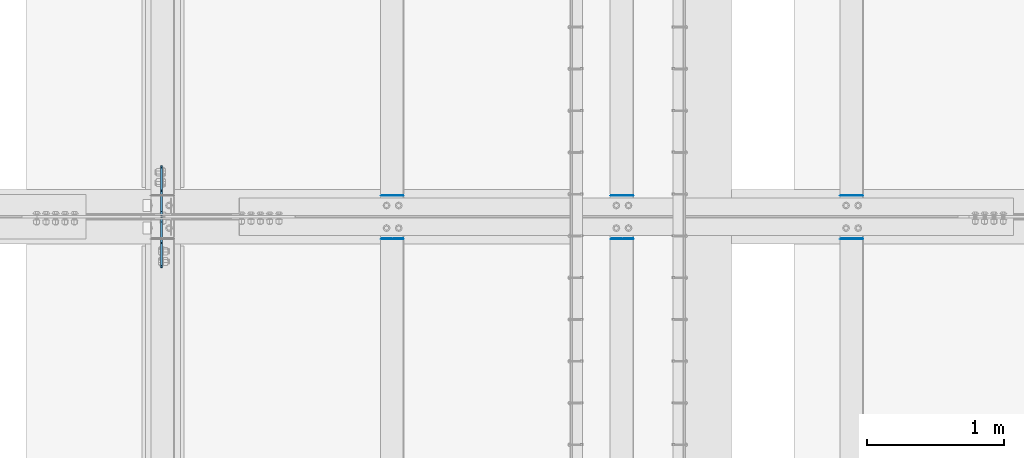
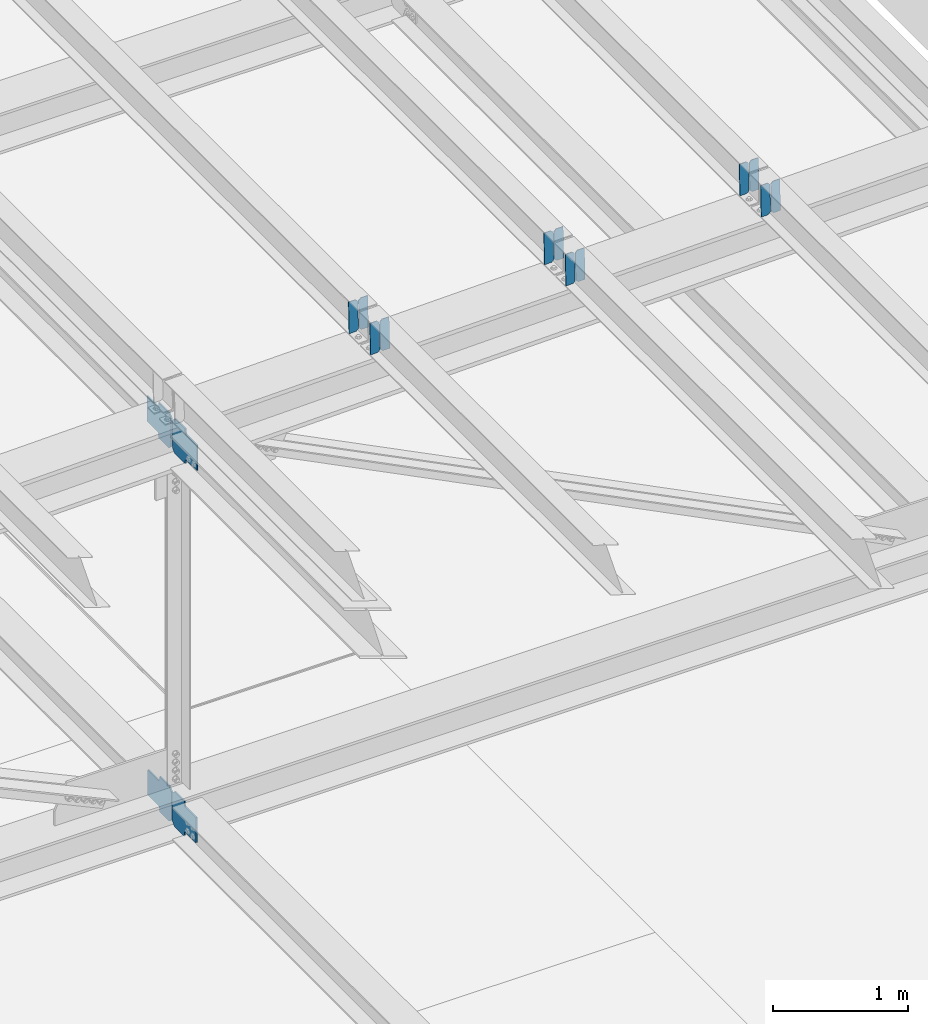
# One storey, part 3306 of 3843: 16 plates, 8 elements without a shape of their own.
"""IFC2X3 building model written with IfcOpenShell, lengths in millimetres."""

from ifc_helpers import new_model, si_unit, frame, origin_with_axes, place, context, subcontext, project, spatial, faceted_brep, material, type_object, element, aggregate, save


model = new_model("IFC2X3")

# Units and contexts
model_context = context("Model", 3, precision=1e-05, world=origin_with_axes())
body_context = subcontext(model_context, "Body", "Model", "MODEL_VIEW")
ifc_project = project(units=[si_unit("LENGTHUNIT", "METRE", prefix="MILLI"), si_unit("AREAUNIT", "SQUARE_METRE"), si_unit("VOLUMEUNIT", "CUBIC_METRE"), si_unit("MASSUNIT", "GRAM", prefix="KILO"), si_unit("TIMEUNIT", "SECOND"), si_unit("PLANEANGLEUNIT", "RADIAN"), si_unit("SOLIDANGLEUNIT", "STERADIAN"), si_unit("THERMODYNAMICTEMPERATUREUNIT", "DEGREE_CELSIUS"), si_unit("LUMINOUSINTENSITYUNIT", "LUMEN")], contexts=[model_context])

# Site, building, storey
site_placement = place(None, origin_with_axes())
site = spatial("IfcSite", under=ifc_project, at=site_placement, CompositionType="ELEMENT")
building_placement = place(site_placement, origin_with_axes())
building = spatial("IfcBuilding", under=site, at=building_placement, Name="Undefined", CompositionType="ELEMENT")
storey_placement = place(building_placement, origin_with_axes())
storey = spatial("IfcBuildingStorey", under=building, at=storey_placement, Name="Undefined", CompositionType="ELEMENT", Elevation=0.0)

# Assembly, plates
assembly_1_placement = place(storey_placement, origin_with_axes())
assembly_1 = element("IfcElementAssembly", 1, at=assembly_1_placement, inside=storey, Name="BEAM", AssemblyPlace="NOTDEFINED", PredefinedType="RIGID_FRAME")
ifc_material = material(Name="STEEL/A572-50")
plate_type_1 = type_object("IfcPlateType", PredefinedType="NOTDEFINED")
plate_1_placement = place(assembly_1_placement, frame((61042.2964783199, 50714.378682198, 46039.4825089286), z_axis=(-0.0211520982859365, -0.000347652999960701, 0.999776208896518), x_axis=(-0.999776269354799, 8.33600001439919e-06, -0.0211520960075334)))
plate_1 = element("IfcPlate", 2, at=plate_1_placement, type_object=plate_type_1, material=ifc_material, Name="PLATE", context=body_context, shape_type="Brep", body=[
    faceted_brep([(0.0, -3.17499999999927, 0.0), (6.83940015733242e-10, -3.17499999996653, 288.924999998613), (6.54836185276508e-10, 3.17500000001746, 288.924999998591), (0.0, 3.17499999999927, 0.0), (60.3250007643655, -3.17500000017753, 288.924999998606), (60.3250007643219, 3.17499999979918, 288.924999998584), (79.3750000013097, -3.17500000025029, 269.875000761494), (79.375000001266, 3.17499999972642, 269.875000761487), (79.375000000713, -3.17500000026484, 19.0499992370605), (79.3750000006985, 3.17499999971187, 19.0499992370533), (60.325000763667, -3.17500000020664, -1.45519152283669e-11), (60.3250007636234, 3.17499999977736, -3.63797880709171e-11)], [[[0, 1, 2, 3]], [[1, 4, 5, 2]], [[4, 6, 7, 5]], [[6, 8, 9, 7]], [[8, 10, 11, 9]], [[10, 0, 3, 11]], [[5, 7, 9, 11, 3, 2]], [[10, 8, 6, 4, 1, 0]]]),
])
plate_2_placement = place(assembly_1_placement, frame((60956.5906576305, 50714.3793127263, 46037.6692454375), z_axis=(-0.0211520982859365, -0.000347652999960701, 0.999776208896518), x_axis=(-0.999776269354799, 8.33600001439919e-06, -0.0211520960075334)))
plate_2 = element("IfcPlate", 3, at=plate_2_placement, type_object=plate_type_1, material=ifc_material, Name="PLATE", context=body_context, shape_type="Brep", body=[
    faceted_brep([(4.36557456851006e-11, -3.17499999998836, 19.0499992370969), (6.11180439591408e-10, -3.17499999996653, 269.875000761516), (5.96628524363041e-10, 3.17500000001746, 269.875000761502), (1.45519152283669e-11, 3.17499999998836, 19.0499992370824), (19.0499992376572, -3.17500000003201, 288.924999998606), (19.0499992376281, 3.1749999999447, 288.924999998584), (79.3750000013242, -3.17500000025029, 288.924999998591), (79.3750000013097, 3.1749999997337, 288.92499999857), (79.3750000006548, -3.17500000026484, -2.18278728425503e-11), (79.3750000006403, 3.17499999969732, -2.91038304567337e-11), (19.0499992370023, -3.17500000005384, 0.0), (19.0499992369587, 3.17499999992287, -1.45519152283669e-11)], [[[0, 1, 2, 3]], [[1, 4, 5, 2]], [[4, 6, 7, 5]], [[6, 8, 9, 7]], [[8, 10, 11, 9]], [[10, 0, 3, 11]], [[5, 7, 9, 11, 3, 2]], [[10, 8, 6, 4, 1, 0]]]),
])
aggregate(assembly_1, [plate_1, plate_2])

assembly_2_placement = place(storey_placement, origin_with_axes())
assembly_2 = element("IfcElementAssembly", 4, at=assembly_2_placement, inside=storey, Name="BEAM", AssemblyPlace="NOTDEFINED", PredefinedType="RIGID_FRAME")
plate_3_placement = place(assembly_2_placement, frame((61042.2964782849, 50397.3143925666, 46039.1367768835), z_axis=(-0.0211520975395179, -0.00180653400038137, 0.999774637208098), x_axis=(-0.999776269352655, 3.88860000353947e-05, -0.0211520620074247)))
plate_3 = element("IfcPlate", 5, at=plate_3_placement, type_object=plate_type_1, material=ifc_material, Name="PLATE", context=body_context, shape_type="Brep", body=[
    faceted_brep([(0.0, -3.17499999999927, 0.0), (6.83940015733242e-10, -3.17499999996653, 288.924999998613), (6.54836185276508e-10, 3.17500000001746, 288.924999998591), (0.0, 3.17499999999927, 0.0), (60.3250007643655, -3.17500000017753, 288.924999998606), (60.3250007643219, 3.17499999979918, 288.924999998584), (79.3750000013097, -3.17500000025029, 269.875000761494), (79.375000001266, 3.17499999972642, 269.875000761487), (79.375000000713, -3.17500000026484, 19.0499992370605), (79.3750000006985, 3.17499999971187, 19.0499992370533), (60.325000763667, -3.17500000020664, -1.45519152283669e-11), (60.3250007636234, 3.17499999977736, -3.63797880709171e-11)], [[[0, 1, 2, 3]], [[1, 4, 5, 2]], [[4, 6, 7, 5]], [[6, 8, 9, 7]], [[8, 10, 11, 9]], [[10, 0, 3, 11]], [[5, 7, 9, 11, 3, 2]], [[10, 8, 6, 4, 1, 0]]]),
])
plate_4_placement = place(assembly_2_placement, frame((60956.5906575955, 50397.3176690209, 46037.323516242), z_axis=(-0.0211520975395179, -0.00180653400038137, 0.999774637208098), x_axis=(-0.999776269352655, 3.88860000353947e-05, -0.0211520620074247)))
plate_4 = element("IfcPlate", 6, at=plate_4_placement, type_object=plate_type_1, material=ifc_material, Name="PLATE", context=body_context, shape_type="Brep", body=[
    faceted_brep([(4.36557456851006e-11, -3.17499999998836, 19.0499992370969), (6.11180439591408e-10, -3.17499999996653, 269.875000761516), (5.96628524363041e-10, 3.17500000001746, 269.875000761502), (1.45519152283669e-11, 3.17499999998836, 19.0499992370824), (19.0499992376572, -3.17500000003201, 288.924999998606), (19.0499992376281, 3.1749999999447, 288.924999998584), (79.3750000013242, -3.17500000025029, 288.924999998591), (79.3750000013097, 3.1749999997337, 288.92499999857), (79.3750000006548, -3.17500000026484, -2.18278728425503e-11), (79.3750000006403, 3.17499999969732, -2.91038304567337e-11), (19.0499992370023, -3.17500000005384, 0.0), (19.0499992369587, 3.17499999992287, -1.45519152283669e-11)], [[[0, 1, 2, 3]], [[1, 4, 5, 2]], [[4, 6, 7, 5]], [[6, 8, 9, 7]], [[8, 10, 11, 9]], [[10, 0, 3, 11]], [[5, 7, 9, 11, 3, 2]], [[10, 8, 6, 4, 1, 0]]]),
])
aggregate(assembly_2, [plate_3, plate_4])

assembly_3_placement = place(storey_placement, origin_with_axes())
assembly_3 = element("IfcElementAssembly", 7, at=assembly_3_placement, inside=storey, Name="BEAM", AssemblyPlace="NOTDEFINED", PredefinedType="RIGID_FRAME")
plate_5_placement = place(assembly_3_placement, frame((59365.8964782974, 50714.3766152781, 46001.2841898124), z_axis=(-0.0211520982357469, -0.000340721000095072, 0.999776211284018), x_axis=(-0.999776269348334, 6.33400000515396e-06, -0.0211520970073544)))
plate_5 = element("IfcPlate", 8, at=plate_5_placement, type_object=plate_type_1, material=ifc_material, Name="PLATE", context=body_context, shape_type="Brep", body=[
    faceted_brep([(0.0, -3.17499999999927, 0.0), (6.83940015733242e-10, -3.17499999996653, 288.924999998613), (6.54836185276508e-10, 3.17500000001746, 288.924999998591), (0.0, 3.17499999999927, 0.0), (60.3250007643655, -3.17500000017753, 288.924999998606), (60.3250007643219, 3.17499999979918, 288.924999998584), (79.3750000013097, -3.17500000025029, 269.875000761494), (79.375000001266, 3.17499999972642, 269.875000761487), (79.375000000713, -3.17500000026484, 19.0499992370605), (79.3750000006985, 3.17499999971187, 19.0499992370533), (60.325000763667, -3.17500000020664, -1.45519152283669e-11), (60.3250007636234, 3.17499999977736, -3.63797880709171e-11)], [[[0, 1, 2, 3]], [[1, 4, 5, 2]], [[4, 6, 7, 5]], [[6, 8, 9, 7]], [[8, 10, 11, 9]], [[10, 0, 3, 11]], [[5, 7, 9, 11, 3, 2]], [[10, 8, 6, 4, 1, 0]]]),
])
plate_6_placement = place(assembly_3_placement, frame((59280.190657608, 50714.3772332324, 45999.4709263163), z_axis=(-0.0211520982357469, -0.000340721000095072, 0.999776211284018), x_axis=(-0.999776269348334, 6.33400000515396e-06, -0.0211520970073544)))
plate_6 = element("IfcPlate", 9, at=plate_6_placement, type_object=plate_type_1, material=ifc_material, Name="PLATE", context=body_context, shape_type="Brep", body=[
    faceted_brep([(4.36557456851006e-11, -3.17499999998836, 19.0499992370969), (6.11180439591408e-10, -3.17499999996653, 269.875000761516), (5.96628524363041e-10, 3.17500000001746, 269.875000761502), (1.45519152283669e-11, 3.17499999998836, 19.0499992370824), (19.0499992376572, -3.17500000003201, 288.924999998606), (19.0499992376281, 3.1749999999447, 288.924999998584), (79.3750000013242, -3.17500000025029, 288.924999998591), (79.3750000013097, 3.1749999997337, 288.92499999857), (79.3750000006548, -3.17500000026484, -2.18278728425503e-11), (79.3750000006403, 3.17499999969732, -2.91038304567337e-11), (19.0499992370023, -3.17500000005384, 0.0), (19.0499992369587, 3.17499999992287, -1.45519152283669e-11)], [[[0, 1, 2, 3]], [[1, 4, 5, 2]], [[4, 6, 7, 5]], [[6, 8, 9, 7]], [[8, 10, 11, 9]], [[10, 0, 3, 11]], [[5, 7, 9, 11, 3, 2]], [[10, 8, 6, 4, 1, 0]]]),
])
aggregate(assembly_3, [plate_5, plate_6])

assembly_4_placement = place(storey_placement, origin_with_axes())
assembly_4 = element("IfcElementAssembly", 10, at=assembly_4_placement, inside=storey, Name="BEAM", AssemblyPlace="NOTDEFINED", PredefinedType="RIGID_FRAME")
plate_7_placement = place(assembly_4_placement, frame((59365.8964782845, 50397.2916688442, 46000.9517746952), z_axis=(-0.0211520976932152, -0.00173049699948751, 0.999774771707764), x_axis=(-0.99977626935114, 3.66869999923657e-05, -0.0211520660073878)))
plate_7 = element("IfcPlate", 11, at=plate_7_placement, type_object=plate_type_1, material=ifc_material, Name="PLATE", context=body_context, shape_type="Brep", body=[
    faceted_brep([(0.0, -3.17499999999927, 0.0), (6.83940015733242e-10, -3.17499999996653, 288.924999998613), (6.54836185276508e-10, 3.17500000001746, 288.924999998591), (0.0, 3.17499999999927, 0.0), (60.3250007643655, -3.17500000017753, 288.924999998606), (60.3250007643219, 3.17499999979918, 288.924999998584), (79.3750000013097, -3.17500000025029, 269.875000761494), (79.375000001266, 3.17499999972642, 269.875000761487), (79.375000000713, -3.17500000026484, 19.0499992370605), (79.3750000006985, 3.17499999971187, 19.0499992370533), (60.325000763667, -3.17500000020664, -1.45519152283669e-11), (60.3250007636234, 3.17499999977736, -3.63797880709171e-11)], [[[0, 1, 2, 3]], [[1, 4, 5, 2]], [[4, 6, 7, 5]], [[6, 8, 9, 7]], [[8, 10, 11, 9]], [[10, 0, 3, 11]], [[5, 7, 9, 11, 3, 2]], [[10, 8, 6, 4, 1, 0]]]),
])
plate_8_placement = place(assembly_4_placement, frame((59280.1906575952, 50397.294807393, 45999.1385138113), z_axis=(-0.0211520976932152, -0.00173049699948751, 0.999774771707764), x_axis=(-0.99977626935114, 3.66869999923657e-05, -0.0211520660073878)))
plate_8 = element("IfcPlate", 12, at=plate_8_placement, type_object=plate_type_1, material=ifc_material, Name="PLATE", context=body_context, shape_type="Brep", body=[
    faceted_brep([(4.36557456851006e-11, -3.17499999998836, 19.0499992370969), (6.11180439591408e-10, -3.17499999996653, 269.875000761516), (5.96628524363041e-10, 3.17500000001746, 269.875000761502), (1.45519152283669e-11, 3.17499999998836, 19.0499992370824), (19.0499992376572, -3.17500000003201, 288.924999998606), (19.0499992376281, 3.1749999999447, 288.924999998584), (79.3750000013242, -3.17500000025029, 288.924999998591), (79.3750000013097, 3.1749999997337, 288.92499999857), (79.3750000006548, -3.17500000026484, -2.18278728425503e-11), (79.3750000006403, 3.17499999969732, -2.91038304567337e-11), (19.0499992370023, -3.17500000005384, 0.0), (19.0499992369587, 3.17499999992287, -1.45519152283669e-11)], [[[0, 1, 2, 3]], [[1, 4, 5, 2]], [[4, 6, 7, 5]], [[6, 8, 9, 7]], [[8, 10, 11, 9]], [[10, 0, 3, 11]], [[5, 7, 9, 11, 3, 2]], [[10, 8, 6, 4, 1, 0]]]),
])
aggregate(assembly_4, [plate_7, plate_8])

assembly_5_placement = place(storey_placement, origin_with_axes())
assembly_5 = element("IfcElementAssembly", 13, at=assembly_5_placement, inside=storey, Name="BEAM", AssemblyPlace="NOTDEFINED", PredefinedType="RIGID_FRAME")
plate_9_placement = place(assembly_5_placement, frame((57689.4964781292, 50714.3658895965, 45962.5609798645), z_axis=(-0.0211520979898778, -0.000304750999974203, 0.999776222900632), x_axis=(-0.999776269348334, 6.33400000515396e-06, -0.0211520970073544)))
plate_9 = element("IfcPlate", 14, at=plate_9_placement, type_object=plate_type_1, material=ifc_material, Name="PLATE", context=body_context, shape_type="Brep", body=[
    faceted_brep([(0.0, -3.17499999999927, 0.0), (6.83940015733242e-10, -3.17499999996653, 288.924999998613), (6.54836185276508e-10, 3.17500000001746, 288.924999998591), (0.0, 3.17499999999927, 0.0), (60.3250007643655, -3.17500000017753, 288.924999998606), (60.3250007643219, 3.17499999979918, 288.924999998584), (79.3750000013097, -3.17500000025029, 269.875000761494), (79.375000001266, 3.17499999972642, 269.875000761487), (79.375000000713, -3.17500000026484, 19.0499992370605), (79.3750000006985, 3.17499999971187, 19.0499992370533), (60.325000763667, -3.17500000020664, -1.45519152283669e-11), (60.3250007636234, 3.17499999977736, -3.63797880709171e-11)], [[[0, 1, 2, 3]], [[1, 4, 5, 2]], [[4, 6, 7, 5]], [[6, 8, 9, 7]], [[8, 10, 11, 9]], [[10, 0, 3, 11]], [[5, 7, 9, 11, 3, 2]], [[10, 8, 6, 4, 1, 0]]]),
])
plate_10_placement = place(assembly_5_placement, frame((57603.7906574399, 50714.3664422284, 45960.7477163476), z_axis=(-0.0211520979898778, -0.000304750999974203, 0.999776222900632), x_axis=(-0.999776269348334, 6.33400000515396e-06, -0.0211520970073544)))
plate_10 = element("IfcPlate", 15, at=plate_10_placement, type_object=plate_type_1, material=ifc_material, Name="PLATE", context=body_context, shape_type="Brep", body=[
    faceted_brep([(4.36557456851006e-11, -3.17499999998836, 19.0499992370969), (6.11180439591408e-10, -3.17499999996653, 269.875000761516), (5.96628524363041e-10, 3.17500000001746, 269.875000761502), (1.45519152283669e-11, 3.17499999998836, 19.0499992370824), (19.0499992376572, -3.17500000003201, 288.924999998606), (19.0499992376281, 3.1749999999447, 288.924999998584), (79.3750000013242, -3.17500000025029, 288.924999998591), (79.3750000013097, 3.1749999997337, 288.92499999857), (79.3750000006548, -3.17500000026484, -2.18278728425503e-11), (79.3750000006403, 3.17499999969732, -2.91038304567337e-11), (19.0499992370023, -3.17500000005384, 0.0), (19.0499992369587, 3.17499999992287, -1.45519152283669e-11)], [[[0, 1, 2, 3]], [[1, 4, 5, 2]], [[4, 6, 7, 5]], [[6, 8, 9, 7]], [[8, 10, 11, 9]], [[10, 0, 3, 11]], [[5, 7, 9, 11, 3, 2]], [[10, 8, 6, 4, 1, 0]]]),
])
aggregate(assembly_5, [plate_9, plate_10])

assembly_6_placement = place(storey_placement, origin_with_axes())
assembly_6 = element("IfcElementAssembly", 16, at=assembly_6_placement, inside=storey, Name="BEAM", AssemblyPlace="NOTDEFINED", PredefinedType="RIGID_FRAME")
plate_11_placement = place(assembly_6_placement, frame((57689.4964782874, 50397.266879727, 45962.2475169509), z_axis=(-0.0211520977282781, -0.00164754199975142, 0.999774911851189), x_axis=(-0.999776269344788, 3.44879999965181e-05, -0.0211520700073351)))
plate_11 = element("IfcPlate", 17, at=plate_11_placement, type_object=plate_type_1, material=ifc_material, Name="PLATE", context=body_context, shape_type="Brep", body=[
    faceted_brep([(0.0, -3.17499999999927, 0.0), (6.83940015733242e-10, -3.17499999996653, 288.924999998613), (6.54836185276508e-10, 3.17500000001746, 288.924999998591), (0.0, 3.17499999999927, 0.0), (60.3250007643655, -3.17500000017753, 288.924999998606), (60.3250007643219, 3.17499999979918, 288.924999998584), (79.3750000013097, -3.17500000025029, 269.875000761494), (79.375000001266, 3.17499999972642, 269.875000761487), (79.375000000713, -3.17500000026484, 19.0499992370605), (79.3750000006985, 3.17499999971187, 19.0499992370533), (60.325000763667, -3.17500000020664, -1.45519152283669e-11), (60.3250007636234, 3.17499999977736, -3.63797880709171e-11)], [[[0, 1, 2, 3]], [[1, 4, 5, 2]], [[4, 6, 7, 5]], [[6, 8, 9, 7]], [[8, 10, 11, 9]], [[10, 0, 3, 11]], [[5, 7, 9, 11, 3, 2]], [[10, 8, 6, 4, 1, 0]]]),
])
plate_12_placement = place(assembly_6_placement, frame((57603.7906575981, 50397.2698678225, 45960.4342558119), z_axis=(-0.0211520977282781, -0.00164754199975142, 0.999774911851189), x_axis=(-0.999776269344788, 3.44879999965181e-05, -0.0211520700073351)))
plate_12 = element("IfcPlate", 18, at=plate_12_placement, type_object=plate_type_1, material=ifc_material, Name="PLATE", context=body_context, shape_type="Brep", body=[
    faceted_brep([(4.36557456851006e-11, -3.17499999998836, 19.0499992370969), (6.11180439591408e-10, -3.17499999996653, 269.875000761516), (5.96628524363041e-10, 3.17500000001746, 269.875000761502), (1.45519152283669e-11, 3.17499999998836, 19.0499992370824), (19.0499992376572, -3.17500000003201, 288.924999998606), (19.0499992376281, 3.1749999999447, 288.924999998584), (79.3750000013242, -3.17500000025029, 288.924999998591), (79.3750000013097, 3.1749999997337, 288.92499999857), (79.3750000006548, -3.17500000026484, -2.18278728425503e-11), (79.3750000006403, 3.17499999969732, -2.91038304567337e-11), (19.0499992370023, -3.17500000005384, 0.0), (19.0499992369587, 3.17499999992287, -1.45519152283669e-11)], [[[0, 1, 2, 3]], [[1, 4, 5, 2]], [[4, 6, 7, 5]], [[6, 8, 9, 7]], [[8, 10, 11, 9]], [[10, 0, 3, 11]], [[5, 7, 9, 11, 3, 2]], [[10, 8, 6, 4, 1, 0]]]),
])
aggregate(assembly_6, [plate_11, plate_12])

assembly_7_placement = place(storey_placement, origin_with_axes())
assembly_7 = element("IfcElementAssembly", 19, at=assembly_7_placement, inside=storey, Name="BEAM", AssemblyPlace="NOTDEFINED", PredefinedType="RIGID_FRAME")
plate_type_2 = type_object("IfcPlateType", PredefinedType="NOTDEFINED")
plate_13_placement = place(assembly_7_placement, frame((55919.6875628394, 50551.556249989, 42202.042585567), z_axis=(0.0, -0.707106781186682, 0.707106781186413), x_axis=(0.0, -0.707106781186548, -0.707106781186548)))
plate_13 = element("IfcPlate", 20, at=plate_13_placement, type_object=plate_type_2, material=ifc_material, Name="PLATE", context=body_context, shape_type="Brep", body=[
    faceted_brep([(0.0, -6.3499999046162, 0.0), (-179.584028640442, -6.34999999999854, 179.584028640433), (-179.584028640442, 6.34999999999854, 179.584028640433), (7.27595761418343e-12, 6.3499999046162, 0.0), (-179.584028640442, -6.34999999999854, 224.485309245561), (-179.584028640442, 6.34999999999854, 224.485309245561), (-75.7498172488849, -6.34999999999854, 328.319520637118), (-75.7498172488849, 6.34999999999854, 328.319520637118), (-53.0798196992109, -6.34999999999854, 305.649523087452), (-53.0798196992109, 6.34999999999854, 305.649523087452), (-48.9596432310645, -6.34999999999854, 302.896509186985), (-48.9596432310645, 6.34999999999854, 302.896509186985), (-44.09956371304, -6.34999999999854, 301.929779264394), (-44.09956371304, 6.34999999999854, 301.929779264394), (-39.2394841950008, -6.34999999999854, 302.896509186985), (-39.2394841950008, 6.34999999999854, 302.896509186985), (-35.1193077268545, -6.34999999999854, 305.649523087452), (-35.1193077268545, 6.34999999999854, 305.649523087452), (77.133893928607, -6.34999999999854, 417.902724742924), (77.133893928607, 6.34999999999854, 417.902724742924), (238.778504107089, -6.34999999999854, 256.25811456446), (238.778504107089, 6.34999999999854, 256.25811456446), (126.525302451613, -6.34999999999854, 144.004912908984), (126.525302451613, 6.34999999999854, 144.004912908984), (123.772288551132, -6.34999999999854, 139.884736440834), (123.772288551132, 6.34999999999854, 139.884736440834), (122.805558628548, -6.34999999999854, 135.024656922806), (122.805558628548, 6.34999999999854, 135.024656922806), (123.772288551132, -6.34999999999854, 130.16457740477), (123.772288551132, 6.34999999999854, 130.16457740477), (126.525302451613, -6.34999999999854, 126.044400936627), (126.525302451613, 6.34999999999854, 126.044400936627), (148.735492004496, -6.35000000000582, 103.834211399357), (148.735492004496, 6.35000000000582, 103.834211399357), (44.9012806051323, -6.35000000000582, -1.45519152283669e-11), (44.9012806051323, 6.35000000000582, -1.45519152283669e-11)], [[[0, 1, 2, 3]], [[1, 4, 5, 2]], [[4, 6, 7, 5]], [[6, 8, 9, 7]], [[8, 10, 11, 9]], [[10, 12, 13, 11]], [[12, 14, 15, 13]], [[14, 16, 17, 15]], [[16, 18, 19, 17]], [[18, 20, 21, 19]], [[20, 22, 23, 21]], [[22, 24, 25, 23]], [[24, 26, 27, 25]], [[26, 28, 29, 27]], [[28, 30, 31, 29]], [[30, 32, 33, 31]], [[32, 34, 35, 33]], [[34, 0, 3, 35]], [[5, 7, 9, 11, 13, 15, 17, 19, 21, 23, 25, 27, 29, 31, 33, 35, 3, 2]], [[34, 32, 30, 28, 26, 24, 22, 20, 18, 16, 14, 12, 10, 8, 6, 4, 1, 0]]]),
])
plate_14_placement = place(assembly_7_placement, frame((55919.6874999693, 50565.84375, 42202.042585421), z_axis=(0.0, 0.707106781186548, 0.707106781186548), x_axis=(5.70000238222118e-08, 0.707106781186546, -0.707106781186546)))
plate_14 = element("IfcPlate", 21, at=plate_14_placement, type_object=plate_type_2, material=ifc_material, Name="PLATE", context=body_context, shape_type="Brep", body=[
    faceted_brep([(0.0, -6.3499999046162, 0.0), (-179.584028640442, -6.34999999999854, 179.584028640433), (-179.584028640442, 6.34999999999854, 179.584028640433), (7.27595761418343e-12, 6.3499999046162, 0.0), (-179.584028640442, -6.34999999999854, 224.485309245561), (-179.584028640442, 6.34999999999854, 224.485309245561), (-75.7498172488849, -6.34999999999854, 328.319520637118), (-75.7498172488849, 6.34999999999854, 328.319520637118), (-53.3753497533908, -6.34999999999854, 305.945053157266), (-53.3753497533908, 6.34999999999854, 305.945053157266), (-49.2551732852553, -6.34999999999854, 303.192039256799), (-49.2551732852553, 6.34999999999854, 303.192039256799), (-44.3950937672162, -6.34999999999854, 302.225309334201), (-44.3950937672162, 6.34999999999854, 302.225309334201), (-39.5350142491807, -6.34999999999854, 303.192039256799), (-39.5350142491807, 6.34999999999854, 303.192039256799), (-35.4148377810343, -6.34999999999854, 305.945053157266), (-35.4148377810343, 6.34999999999854, 305.945053157266), (76.8383638666346, -6.34999999999854, 418.198254804927), (76.8383638666346, 6.34999999999854, 418.198254804927), (238.482974045106, -6.34999999999854, 256.55364462646), (238.482974045106, 6.34999999999854, 256.55364462646), (126.229772397422, -6.34999999999854, 144.300442978798), (126.229772397422, 6.34999999999854, 144.300442978798), (123.476758496952, -6.34999999999854, 140.180266510652), (123.476758496952, 6.34999999999854, 140.180266510652), (122.510028574368, -6.34999999999854, 135.320186992612), (122.510028574368, 6.34999999999854, 135.320186992612), (123.476758496952, -6.34999999999854, 130.460107474588), (123.476758496952, 6.34999999999854, 130.460107474588), (126.229772397426, -6.34999999999854, 126.339931006427), (126.229772397426, 6.34999999999854, 126.339931006427), (148.735492004496, -6.35000000000582, 103.834211399357), (148.735492004496, 6.35000000000582, 103.834211399357), (44.9012806051323, -6.35000000000582, -1.45519152283669e-11), (44.9012806051323, 6.35000000000582, -1.45519152283669e-11)], [[[0, 1, 2, 3]], [[1, 4, 5, 2]], [[4, 6, 7, 5]], [[6, 8, 9, 7]], [[8, 10, 11, 9]], [[10, 12, 13, 11]], [[12, 14, 15, 13]], [[14, 16, 17, 15]], [[16, 18, 19, 17]], [[18, 20, 21, 19]], [[20, 22, 23, 21]], [[22, 24, 25, 23]], [[24, 26, 27, 25]], [[26, 28, 29, 27]], [[28, 30, 31, 29]], [[30, 32, 33, 31]], [[32, 34, 35, 33]], [[34, 0, 3, 35]], [[5, 7, 9, 11, 13, 15, 17, 19, 21, 23, 25, 27, 29, 31, 33, 35, 3, 2]], [[34, 32, 30, 28, 26, 24, 22, 20, 18, 16, 14, 12, 10, 8, 6, 4, 1, 0]]]),
])
aggregate(assembly_7, [plate_13, plate_14])

assembly_8_placement = place(storey_placement, origin_with_axes())
assembly_8 = element("IfcElementAssembly", 22, at=assembly_8_placement, inside=storey, Name="BEAM", AssemblyPlace="NOTDEFINED", PredefinedType="RIGID_FRAME")
plate_15_placement = place(assembly_8_placement, frame((55919.6874999692, 50547.5875000047, 45586.359998905), z_axis=(0.0, -0.707106781186682, 0.707106781186413), x_axis=(0.0, -0.707106781186548, -0.707106781186548)))
plate_15 = element("IfcPlate", 23, at=plate_15_placement, type_object=plate_type_2, material=ifc_material, Name="PLATE", context=body_context, shape_type="Brep", body=[
    faceted_brep([(0.0, -6.3499999046162, 0.0), (-179.455861999822, -6.34999999999854, 179.455861999886), (-179.455861999822, 6.34999999999854, 179.455861999886), (7.27595761418343e-12, 6.3499999046162, 0.0), (-179.45586199936, -6.34999999999854, 224.35714260547), (-179.45586199936, 6.34999999999854, 224.35714260547), (-68.3251924993656, -6.34999999999854, 335.487812105435), (-68.3251924993656, 6.34999999999854, 335.487812105435), (-45.8510327417989, -6.34999999999854, 313.013652347858), (-45.8510327417989, 6.34999999999854, 313.013652347858), (-41.7308562736453, -6.34999999999854, 310.260638447406), (-41.7308562736453, 6.34999999999854, 310.260638447406), (-36.8707767555916, -6.34999999999854, 309.293908524836), (-36.8707767555916, 6.34999999999854, 309.293908524836), (-32.0106972375306, -6.34999999999854, 310.260638447449), (-32.0106972375306, 6.34999999999854, 310.260638447449), (-27.8905207693479, -6.34999999999854, 313.013652347945), (-27.8905207693479, 6.34999999999854, 313.013652347945), (84.3626808807439, -6.34999999999854, 425.266853998022), (84.3626808807439, 6.34999999999854, 425.266853998022), (246.00729105919, -6.34999999999854, 263.622243819555), (246.00729105919, 6.34999999999854, 263.622243819555), (133.754089409091, -6.34999999999854, 151.369042169477), (133.754089409091, 6.34999999999854, 151.369042169477), (131.001075508588, -6.34999999999854, 147.248865701302), (131.001075508588, 6.34999999999854, 147.248865701302), (130.034345585982, -6.34999999999854, 142.388786183248), (130.034345585982, 6.34999999999854, 142.388786183248), (131.001075508537, -6.34999999999854, 137.52870666518), (131.001075508537, 6.34999999999854, 137.52870666518), (133.754089408996, -6.34999999999854, 133.408530197034), (133.754089408996, 6.34999999999854, 133.408530197034), (156.031950102829, -6.35000000000582, 111.130669497703), (156.031950102829, 6.35000000000582, 111.130669497703), (44.9012806051323, -6.35000000000582, -1.45519152283669e-11), (44.9012806051323, 6.35000000000582, -1.45519152283669e-11)], [[[0, 1, 2, 3]], [[1, 4, 5, 2]], [[4, 6, 7, 5]], [[6, 8, 9, 7]], [[8, 10, 11, 9]], [[10, 12, 13, 11]], [[12, 14, 15, 13]], [[14, 16, 17, 15]], [[16, 18, 19, 17]], [[18, 20, 21, 19]], [[20, 22, 23, 21]], [[22, 24, 25, 23]], [[24, 26, 27, 25]], [[26, 28, 29, 27]], [[28, 30, 31, 29]], [[30, 32, 33, 31]], [[32, 34, 35, 33]], [[34, 0, 3, 35]], [[5, 7, 9, 11, 13, 15, 17, 19, 21, 23, 25, 27, 29, 31, 33, 35, 3, 2]], [[34, 32, 30, 28, 26, 24, 22, 20, 18, 16, 14, 12, 10, 8, 6, 4, 1, 0]]]),
])
plate_16_placement = place(assembly_8_placement, frame((55919.6874999635, 50569.8125, 45586.3599988584), z_axis=(0.0, 0.707106781186548, 0.707106781186548), x_axis=(5.70000238222118e-08, 0.707106781186546, -0.707106781186546)))
plate_16 = element("IfcPlate", 24, at=plate_16_placement, type_object=plate_type_2, material=ifc_material, Name="PLATE", context=body_context, shape_type="Brep", body=[
    faceted_brep([(0.0, -6.3499999046162, 0.0), (-179.455861999822, -6.34999999999854, 179.455861999886), (-179.455861999822, 6.34999999999854, 179.455861999886), (7.27595761418343e-12, 6.3499999046162, 0.0), (-179.45586199936, -6.34999999999854, 224.35714260547), (-179.45586199936, 6.34999999999854, 224.35714260547), (-68.3251924993656, -6.34999999999854, 335.487812105435), (-68.3251924993656, 6.34999999999854, 335.487812105435), (-46.1841231244034, -6.34999999999854, 313.346742823274), (-46.1841231244034, 6.34999999999854, 313.346742823274), (-42.0639466562279, -6.34999999999854, 310.593728922808), (-42.0639466562279, 6.34999999999854, 310.593728922808), (-37.2038671381597, -6.34999999999854, 309.626999000238), (-37.2038671381597, 6.34999999999854, 309.626999000238), (-32.3437876200915, -6.34999999999854, 310.59372892287), (-32.3437876200915, 6.34999999999854, 310.59372892287), (-28.2236111519014, -6.34999999999854, 313.346742823402), (-28.2236111519014, 6.34999999999854, 313.346742823402), (84.0295904487139, -6.34999999999854, 425.599944425017), (84.0295904487139, 6.34999999999854, 425.599944425017), (245.674200627895, -6.34999999999854, 263.955334245589), (245.674200627895, 6.34999999999854, 263.955334245589), (133.420999027163, -6.34999999999854, 151.702132643879), (133.420999027163, 6.34999999999854, 151.702132643879), (130.667985126682, -6.34999999999854, 147.581956175703), (130.667985126682, 6.34999999999854, 147.581956175703), (129.701255204083, -6.34999999999854, 142.721876657653), (129.701255204083, 6.34999999999854, 142.721876657653), (130.667985126638, -6.34999999999854, 137.861797139618), (130.667985126638, 6.34999999999854, 137.861797139618), (133.420999027105, -6.34999999999854, 133.741620671475), (133.420999027105, 6.34999999999854, 133.741620671475), (156.031950102829, -6.35000000000582, 111.130669497703), (156.031950102829, 6.35000000000582, 111.130669497703), (44.9012806051323, -6.35000000000582, -1.45519152283669e-11), (44.9012806051323, 6.35000000000582, -1.45519152283669e-11)], [[[0, 1, 2, 3]], [[1, 4, 5, 2]], [[4, 6, 7, 5]], [[6, 8, 9, 7]], [[8, 10, 11, 9]], [[10, 12, 13, 11]], [[12, 14, 15, 13]], [[14, 16, 17, 15]], [[16, 18, 19, 17]], [[18, 20, 21, 19]], [[20, 22, 23, 21]], [[22, 24, 25, 23]], [[24, 26, 27, 25]], [[26, 28, 29, 27]], [[28, 30, 31, 29]], [[30, 32, 33, 31]], [[32, 34, 35, 33]], [[34, 0, 3, 35]], [[5, 7, 9, 11, 13, 15, 17, 19, 21, 23, 25, 27, 29, 31, 33, 35, 3, 2]], [[34, 32, 30, 28, 26, 24, 22, 20, 18, 16, 14, 12, 10, 8, 6, 4, 1, 0]]]),
])
aggregate(assembly_8, [plate_15, plate_16])

save(model, "model.ifc")
